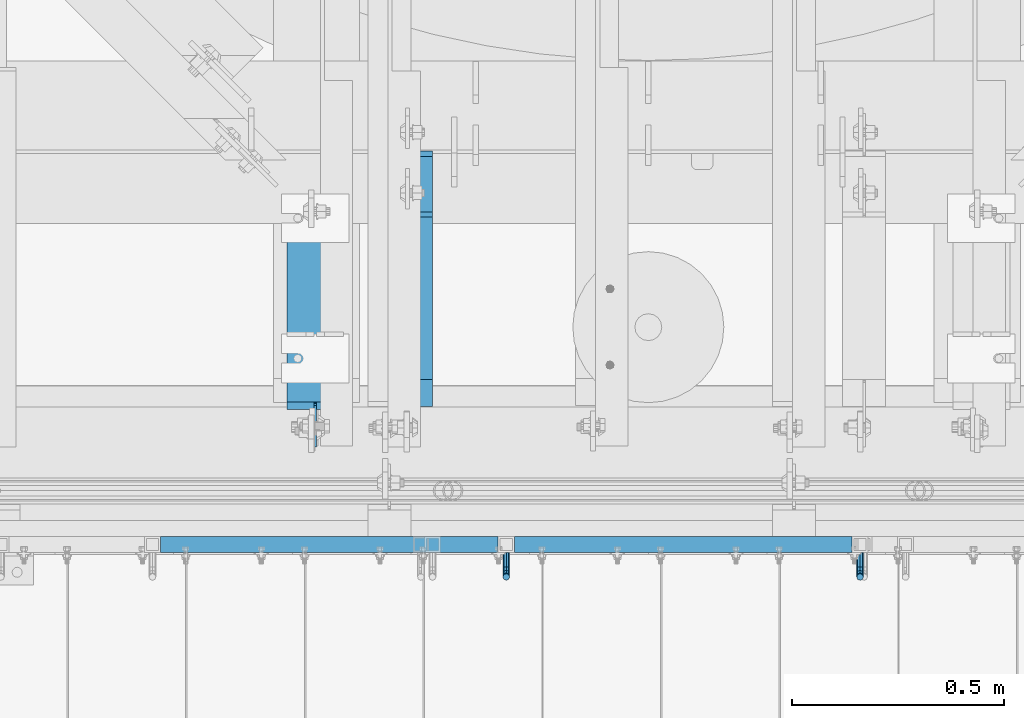
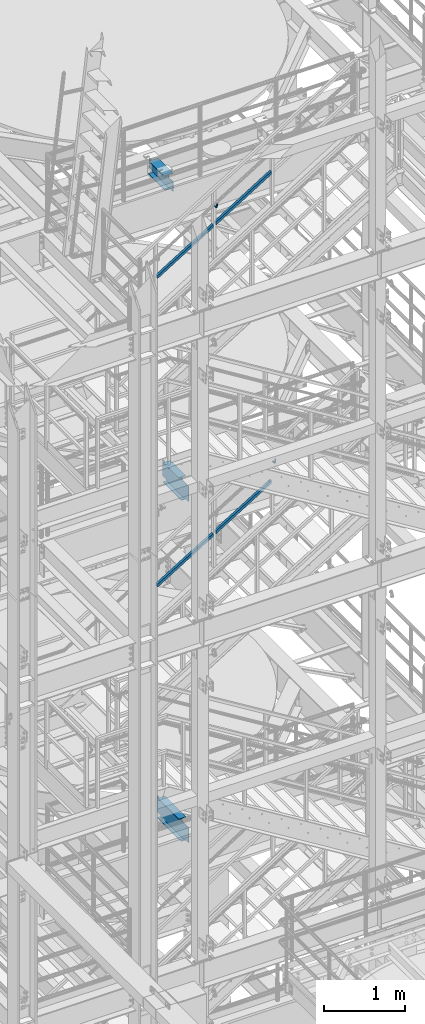
# One storey, part 1191 of 1876: 5 beams, 4 members, 5 elements without a shape of their own.
"""IFC2X3 building model written with IfcOpenShell, lengths in millimetres."""

from ifc_helpers import new_model, si_unit, frame, origin_with_axes, place, context, subcontext, project, spatial, faceted_brep, material, type_object, element, aggregate, save


model = new_model("IFC2X3")

# Units and contexts
model_context = context("Model", 3, precision=1e-05, world=origin_with_axes())
body_context = subcontext(model_context, "Body", "Model", "MODEL_VIEW")
ifc_project = project(units=[si_unit("LENGTHUNIT", "METRE", prefix="MILLI"), si_unit("AREAUNIT", "SQUARE_METRE"), si_unit("VOLUMEUNIT", "CUBIC_METRE"), si_unit("MASSUNIT", "GRAM", prefix="KILO"), si_unit("TIMEUNIT", "SECOND"), si_unit("PLANEANGLEUNIT", "RADIAN"), si_unit("SOLIDANGLEUNIT", "STERADIAN"), si_unit("THERMODYNAMICTEMPERATUREUNIT", "DEGREE_CELSIUS"), si_unit("LUMINOUSINTENSITYUNIT", "LUMEN")], contexts=[model_context])

# Site, building, storey
site_placement = place(None, origin_with_axes())
site = spatial("IfcSite", under=ifc_project, at=site_placement, CompositionType="ELEMENT")
building_placement = place(site_placement, origin_with_axes())
building = spatial("IfcBuilding", under=site, at=building_placement, Name="Undefined", CompositionType="ELEMENT")
storey_placement = place(building_placement, origin_with_axes())
storey = spatial("IfcBuildingStorey", under=building, at=storey_placement, Name="Undefined", CompositionType="ELEMENT", Elevation=0.0)

# Assembly, beam
assembly_1_placement = place(storey_placement, origin_with_axes())
assembly_1 = element("IfcElementAssembly", 1, at=assembly_1_placement, inside=storey, Name="BEAM", AssemblyPlace="NOTDEFINED", PredefinedType="RIGID_FRAME")
ifc_material_1 = material(Name="STEEL/A992")
beam_type_1 = type_object("IfcBeamType", Name="W12X16", PredefinedType="NOTDEFINED")
beam_1_placement = place(assembly_1_placement, frame((3860.8, -4572.0, 13157.2), z_axis=(0.0, 0.0, 1.0), x_axis=(0.0, 1.0, 0.0)))
beam_1 = element("IfcBeam", 2, at=beam_1_placement, type_object=beam_type_1, material=ifc_material_1, Name="BEAM", ObjectType="W12X16", context=body_context, shape_type="Brep", body=[
    faceted_brep([(573.881250000001, -3.17500000000018, -146.049999999999), (573.881250000001, -50.8000000000002, -146.049999999999), (573.881250000001, -50.8000000000002, -152.4), (573.881250000001, 50.8000000000002, -152.4), (573.881250000001, 50.8000000000002, -146.049999999999), (573.881250000001, 3.17500000000018, -146.049999999999), (573.881250000001, 3.17500000000018, -139.699999809265), (573.881250000001, -3.17500000000018, -139.699999809265), (574.847979922589, 3.17500000000018, -134.839920291219), (574.847979922589, -3.17500000000018, -134.839920291219), (577.600993823067, 3.17500000000018, -130.719743823065), (577.600993823067, -3.17500000000018, -130.719743823065), (581.72117029122, 3.17500000000018, -127.966729922588), (581.72117029122, -3.17500000000018, -127.966729922588), (586.581249809266, 3.17500000000018, -127.0), (586.581249809266, -3.17500000000018, -127.0), (662.78125, -3.17500000000018, -127.0), (662.78125, 3.17500000000018, -127.0), (179.3875, 3.17500000000018, 146.049999999999), (179.3875, 50.8000000000002, 146.049999999999), (561.181250000001, 50.8000000000002, 146.049999999999), (561.181250000001, 3.17500000000018, 146.049999999999), (115.8875, -3.17500000000018, -139.699999809263), (115.8875, 3.17500000000018, -139.699999809263), (115.8875, 3.17500000000018, -146.049999999999), (115.8875, 50.8000000000002, -146.049999999999), (115.8875, 50.8000000000002, -152.4), (115.8875, -50.8000000000002, -152.4), (115.8875, -50.8000000000002, -146.049999999999), (115.8875, -3.17500000000018, -146.049999999999), (114.920770077412, -3.17500000000018, -134.839920291217), (114.920770077412, 3.17500000000018, -134.839920291217), (112.167756176934, -3.17500000000018, -130.719743823063), (112.167756176934, 3.17500000000018, -130.719743823063), (108.04757970878, -3.17500000000018, -127.966729922586), (108.04757970878, 3.17500000000018, -127.966729922586), (103.187500190735, -3.17500000000018, -126.999999999998), (103.187500190735, 3.17500000000018, -126.999999999998), (20.6374999999998, -3.17500000000018, -126.999999999998), (20.6374999999998, 3.17500000000018, -126.999999999998), (20.6374999999998, -3.17500000000018, 101.600000000002), (20.6374999999998, 3.17500000000018, 101.600000000002), (166.687500190735, -3.17500000000018, 101.600000000002), (166.687500190735, 3.17500000000018, 101.600000000002), (171.54757970878, -3.17500000000018, 102.56672992259), (171.54757970878, 3.17500000000018, 102.56672992259), (175.667756176934, -3.17500000000018, 105.319743823067), (175.667756176934, 3.17500000000018, 105.319743823067), (178.420770077412, -3.17500000000018, 109.439920291221), (178.420770077412, 3.17500000000018, 109.439920291221), (179.3875, -3.17500000000018, 114.299999809267), (179.3875, 3.17500000000018, 114.299999809267), (179.3875, -50.8000000000002, 152.4), (179.3875, 50.8000000000002, 152.4), (179.3875, -3.17500000000018, 146.049999999999), (179.3875, -50.8000000000002, 146.049999999999), (561.181250000001, -3.17500000000018, 146.049999999999), (561.181250000001, -50.8000000000002, 146.049999999999), (561.181250000001, -50.8000000000002, 152.4), (561.181250000001, 50.8000000000002, 152.4), (561.181250000001, -3.17500000000018, 133.349999809265), (561.181250000001, 3.17500000000018, 133.349999809265), (562.147979922589, -3.17500000000018, 128.489920291218), (562.147979922589, 3.17500000000018, 128.489920291218), (564.900993823067, -3.17500000000018, 124.369743823065), (564.900993823067, 3.17500000000018, 124.369743823065), (569.021170291221, -3.17500000000018, 121.616729922587), (569.021170291221, 3.17500000000018, 121.616729922587), (573.881249809266, -3.17500000000018, 120.65), (573.881249809266, 3.17500000000018, 120.65), (662.78125, -3.17500000000018, 120.65), (662.78125, 3.17500000000018, 120.65)], [[[0, 1, 2, 3, 4, 5, 6, 7]], [[7, 6, 8, 9]], [[9, 8, 10, 11]], [[11, 10, 12, 13]], [[13, 12, 14, 15]], [[16, 15, 14, 17]], [[18, 19, 20, 21]], [[22, 23, 24, 25, 26, 27, 28, 29]], [[30, 31, 23, 22]], [[32, 33, 31, 30]], [[34, 35, 33, 32]], [[36, 37, 35, 34]], [[38, 39, 37, 36]], [[40, 41, 39, 38]], [[42, 43, 41, 40]], [[44, 45, 43, 42]], [[46, 47, 45, 44]], [[48, 49, 47, 46]], [[50, 51, 49, 48]], [[52, 53, 19, 18, 51, 50, 54, 55]], [[55, 54, 56, 57]], [[52, 55, 57, 58]], [[53, 52, 58, 59]], [[19, 53, 59, 20]], [[58, 57, 56, 60, 61, 21, 20, 59]], [[62, 63, 61, 60]], [[64, 65, 63, 62]], [[66, 67, 65, 64]], [[68, 69, 67, 66]], [[70, 71, 69, 68]], [[71, 70, 16, 17]], [[12, 10, 8, 6, 5, 24, 23, 31, 33, 35, 37, 39, 41, 43, 45, 47, 49, 51, 18, 21, 61, 63, 65, 67, 69, 71, 17, 14]], [[25, 24, 5, 4]], [[26, 25, 4, 3]], [[27, 26, 3, 2]], [[28, 27, 2, 1]], [[29, 28, 1, 0]], [[70, 68, 66, 64, 62, 60, 56, 54, 50, 48, 46, 44, 42, 40, 38, 36, 34, 32, 30, 22, 29, 0, 7, 9, 11, 13, 15, 16]]]),
])
aggregate(assembly_1, [beam_1])

assembly_2_placement = place(storey_placement, origin_with_axes())
assembly_2 = element("IfcElementAssembly", 3, at=assembly_2_placement, inside=storey, Name="BEAM", AssemblyPlace="NOTDEFINED", PredefinedType="RIGID_FRAME")
beam_2_placement = place(assembly_2_placement, frame((3860.8, -4572.0, 8001.0), z_axis=(0.0, 0.0, 1.0), x_axis=(0.0, 1.0, 0.0)))
beam_2 = element("IfcBeam", 4, at=beam_2_placement, type_object=beam_type_1, material=ifc_material_1, Name="BEAM", ObjectType="W12X16", context=body_context, shape_type="Brep", body=[
    faceted_brep([(716.75625, -3.17500000000018, -146.05), (716.75625, -50.8000000000002, -146.05), (716.75625, -50.8000000000002, -152.4), (716.75625, 50.8000000000002, -152.4), (716.75625, 50.8000000000002, -146.05), (716.75625, 3.17500001244935, -146.05), (716.75625, 3.17500003927307, -139.699999809264), (716.75625, -3.17500000000018, -139.699999809264), (717.722979922588, 3.17500003847817, -134.839920291219), (717.722979922588, -3.17500000000018, -134.839920291219), (720.475993823066, 3.17500003779696, -130.719743823065), (720.475993823066, -3.17500000000018, -130.719743823065), (724.59617029122, 3.17500003733312, -127.966729922587), (724.59617029122, -3.17500000000018, -127.966729922587), (729.456249809265, 3.17500003715577, -126.999999999999), (729.456249809265, -3.17500000000018, -126.999999999999), (805.65625, -3.17500000000018, -126.999999999999), (805.65625, 3.17500000000018, -126.999999999999), (181.768749999998, 3.17499999999995, 146.05), (181.768749999998, 50.8, 146.05), (704.05625, 50.8000000000002, 146.05), (704.05625, 3.17500000000018, 146.05), (124.61875, 50.8, -146.05), (124.61875, 50.8, -152.4), (124.61875, 3.17500009536752, -152.4), (124.61875, 3.17500009536752, -146.05), (118.268749999998, 3.17500009536752, -152.4), (118.268749999998, 3.17500008940715, -146.05), (118.268749999998, -3.17499999999995, -139.699999809265), (118.268749999998, 3.17500002616043, -139.699999809265), (118.268749999998, -50.8, -152.4), (118.268749999998, -50.8, -146.05), (118.268749999998, -3.17499999999995, -146.05), (117.302020077411, -3.17499999999995, -134.83992029122), (117.302020077411, 3.17500002537099, -134.83992029122), (114.549006176932, -3.17499999999995, -130.719743823066), (114.549006176932, 3.17500002470138, -130.719743823066), (110.428829708779, -3.17499999999995, -127.966729922588), (110.428829708779, 3.17500002425345, -127.966729922588), (105.568750190733, -3.17499999999995, -127.0), (105.568750190733, 3.17500002409543, -127.0), (23.0187500000002, -3.17499999999995, -127.0), (23.0187500000002, 3.17499999999995, -127.0), (23.0187500000002, -3.17499999999995, 101.6), (23.0187500000002, 3.17499999999995, 101.6), (169.068750190733, -3.17499999999995, 101.6), (169.068750190733, 3.17499998798007, 101.6), (173.928829708779, -3.17499999999995, 102.566729922588), (173.928829708779, 3.17499998782432, 102.566729922588), (178.049006176932, -3.17499999999995, 105.319743823066), (178.049006176932, 3.17499998738072, 105.319743823066), (180.802020077411, -3.17499999999995, 109.43992029122), (180.802020077411, 3.17499998671678, 109.43992029122), (181.768749999998, -3.17499999999995, 114.299999809266), (181.768749999998, 3.17499998593348, 114.299999809266), (181.768749999998, -50.8, 152.4), (181.768749999998, 50.8, 152.4), (181.768749999998, -3.17499999999995, 146.05), (181.768749999998, -50.8, 146.05), (704.05625, -3.17500000000018, 146.05), (704.05625, -50.8000000000002, 146.05), (704.05625, -50.8000000000002, 152.4), (704.05625, 50.8000000000002, 152.4), (704.05625, -3.17500000000018, 133.349999809266), (704.05625, 3.1749999952408, 133.349999809266), (705.022979922588, -3.17500000000018, 128.48992029122), (705.022979922588, 3.17499999601478, 128.48992029122), (707.775993823066, -3.17500000000018, 124.369743823067), (707.775993823066, 3.17499999666416, 124.369743823067), (711.89617029122, -3.17500000000018, 121.616729922588), (711.89617029122, 3.1749999970898, 121.616729922588), (716.756249809265, -3.17500000000018, 120.650000000001), (716.756249809265, 3.17499999722713, 120.650000000001), (805.65625, -3.17500000000018, 120.650000000001), (805.65625, 3.17500000000018, 120.650000000001)], [[[0, 1, 2, 3, 4, 5, 6, 7]], [[7, 6, 8, 9]], [[9, 8, 10, 11]], [[11, 10, 12, 13]], [[13, 12, 14, 15]], [[16, 15, 14, 17]], [[18, 19, 20, 21]], [[22, 23, 24, 25]], [[25, 24, 26, 27]], [[28, 29, 27, 26, 30, 31, 32]], [[33, 34, 29, 28]], [[35, 36, 34, 33]], [[37, 38, 36, 35]], [[39, 40, 38, 37]], [[41, 42, 40, 39]], [[43, 44, 42, 41]], [[45, 46, 44, 43]], [[47, 48, 46, 45]], [[49, 50, 48, 47]], [[51, 52, 50, 49]], [[53, 54, 52, 51]], [[55, 56, 19, 18, 54, 53, 57, 58]], [[58, 57, 59, 60]], [[55, 58, 60, 61]], [[56, 55, 61, 62]], [[19, 56, 62, 20]], [[61, 60, 59, 63, 64, 21, 20, 62]], [[65, 66, 64, 63]], [[67, 68, 66, 65]], [[69, 70, 68, 67]], [[71, 72, 70, 69]], [[73, 74, 72, 71]], [[74, 73, 16, 17]], [[12, 10, 8, 6, 5, 25, 27, 29, 34, 36, 38, 40, 42, 44, 46, 48, 50, 52, 54, 18, 21, 64, 66, 68, 70, 72, 74, 17, 14]], [[22, 25, 5, 4]], [[23, 22, 4, 3]], [[30, 26, 24, 23, 3, 2]], [[31, 30, 2, 1]], [[32, 31, 1, 0]], [[73, 71, 69, 67, 65, 63, 59, 57, 53, 51, 49, 47, 45, 43, 41, 39, 37, 35, 33, 28, 32, 0, 7, 9, 11, 13, 15, 16]]]),
])
aggregate(assembly_2, [beam_2])

assembly_3_placement = place(storey_placement, origin_with_axes())
assembly_3 = element("IfcElementAssembly", 5, at=assembly_3_placement, inside=storey, Name="RAIL", AssemblyPlace="NOTDEFINED", PredefinedType="RIGID_FRAME")
ifc_material_2 = material(Name="STEEL/A36")
beam_type_2 = type_object("IfcBeamType", PredefinedType="NOTDEFINED")
beam_3_placement = place(assembly_3_placement, frame((4918.07499998295, -4800.59999885446, 13420.0225827667), z_axis=(1.0, 0.0, 0.0), x_axis=(0.0, -1.0, 0.0)))
beam_3 = element("IfcBeam", 6, at=beam_3_placement, type_object=beam_type_2, material=ifc_material_2, Name="BRACKET", context=body_context, shape_type="Brep", body=[
    faceted_brep([(0.0, -5.61266007566822, 5.61266007566883), (0.0, 0.0, 7.9375), (0.0, 5.61266007566822, 5.61266007566883), (0.0, 7.9375, 0.0), (0.0, 5.61266007566822, -5.61266007566883), (0.0, 0.0, -7.9375), (0.0, -5.61266007566822, -5.61266007566883), (0.0, -7.9375, 0.0), (23.8125, 5.61266007566883, 5.61266007566792), (23.8125, 7.9375, 0.0), (23.8125, 5.61266007566883, -5.61266007566792), (23.8125, 0.0, -7.9375), (23.8125, -5.61266007566883, -5.61266007566792), (23.8125, -7.9375, 0.0), (23.8125, -5.61266007566883, 5.61266007566792), (23.8125, 0.0, 7.9375), (36.5702095103989, -2.53766620105534, 7.9375), (38.7180815328547, 2.64775556579752, 5.61266007566792), (39.6077592547972, 4.79562758825296, 0.0), (38.7180815328547, 2.64775556579752, -5.61266007566792), (36.5702095103989, -2.53766620105534, -7.9375), (34.4223374879439, -7.72308796790867, -5.61266007566792), (33.5326597660014, -9.87095999036364, 0.0), (34.4223374879439, -7.72308796790867, 5.61266007566792), (43.4169233967659, -13.733078129113, 5.61266007566792), (47.385673396765, -9.76432812911298, 7.9375), (41.7730133210971, -15.3769882047809, 0.0), (43.4169233967659, -13.733078129113, -5.61266007566792), (47.385673396765, -9.76432812911298, -7.9375), (51.354423396765, -5.79557812911253, -5.61266007566792), (52.9983334724338, -4.15166805344461, 0.0), (51.354423396765, -5.79557812911253, 5.61266007566792), (54.6123353248231, -20.5797920154787, 7.9375), (59.7977570916764, -18.4319199930233, 5.61266007566792), (49.4269135579698, -22.7276640379341, 5.61266007566792), (47.2790415355148, -23.6173417598766, 0.0), (49.4269135579698, -22.7276640379341, -5.61266007566792), (54.6123353248231, -20.5797920154787, -7.9375), (59.7977570916764, -18.4319199930233, -5.61266007566792), (61.9456291141314, -17.5422422710808, 0.0), (62.7626616015468, -33.3375015258789, 5.61266007566792), (65.0875015258789, -33.3375015258789, 0.0), (57.1500015258789, -33.3375015258789, 7.9375), (51.5373414502101, -33.3375015258789, 5.61266007566792), (49.2125015258789, -33.3375015258789, 0.0), (51.5373414502101, -33.3375015258789, -5.61266007566792), (57.1500015258789, -33.3375015258789, -7.9375), (62.7626616015468, -33.3375015258789, -5.61266007566792), (65.0875015258789, -66.5341532333514, 2.45290721068159e-09), (62.7626616015805, -63.0815171359536, -5.61266007334871), (57.1500015259289, -61.6513884384531, -7.93749999776537), (51.5373414502437, -63.0815171359118, -5.6126600734151), (49.2125015258789, -66.5341532333259, 2.41197994910181e-09), (51.5373414501864, -69.9867893307037, 5.61266007818085), (57.1500015258471, -71.4169180281988, 7.93750000258842), (62.7626616015223, -69.9867893307346, 5.61266007822906)], [[[0, 1, 2, 3, 4, 5, 6, 7]], [[3, 2, 8, 9]], [[4, 3, 9, 10]], [[5, 4, 10, 11]], [[6, 5, 11, 12]], [[7, 6, 12, 13]], [[0, 7, 13, 14]], [[1, 0, 14, 15]], [[2, 1, 15, 8]], [[8, 15, 16, 17]], [[9, 8, 17, 18]], [[10, 9, 18, 19]], [[11, 10, 19, 20]], [[12, 11, 20, 21]], [[13, 12, 21, 22]], [[14, 13, 22, 23]], [[15, 14, 23, 16]], [[23, 24, 25, 16]], [[22, 26, 24, 23]], [[21, 27, 26, 22]], [[20, 28, 27, 21]], [[19, 29, 28, 20]], [[18, 30, 29, 19]], [[17, 31, 30, 18]], [[16, 25, 31, 17]], [[25, 32, 33, 31]], [[24, 34, 32, 25]], [[26, 35, 34, 24]], [[27, 36, 35, 26]], [[28, 37, 36, 27]], [[29, 38, 37, 28]], [[30, 39, 38, 29]], [[31, 33, 39, 30]], [[33, 40, 41, 39]], [[32, 42, 40, 33]], [[34, 43, 42, 32]], [[35, 44, 43, 34]], [[36, 45, 44, 35]], [[37, 46, 45, 36]], [[38, 47, 46, 37]], [[39, 41, 47, 38]], [[47, 41, 48, 49]], [[46, 47, 49, 50]], [[45, 46, 50, 51]], [[44, 45, 51, 52]], [[43, 44, 52, 53]], [[42, 43, 53, 54]], [[40, 42, 54, 55]], [[41, 40, 55, 48]], [[54, 53, 52, 51, 50, 49, 48, 55]]]),
])

assembly_4_placement = place(storey_placement, origin_with_axes())
assembly_4 = element("IfcElementAssembly", 7, at=assembly_4_placement, inside=storey, Name="RAIL", AssemblyPlace="NOTDEFINED", PredefinedType="RIGID_FRAME")
beam_4_placement = place(assembly_4_placement, frame((4085.16666479088, -4800.60000114554, 17572.4589985402), z_axis=(-1.0, 0.0, 0.0), x_axis=(0.0, -1.0, 0.0)))
beam_4 = element("IfcBeam", 8, at=beam_4_placement, type_object=beam_type_2, material=ifc_material_2, Name="BRACKET", context=body_context, shape_type="Brep", body=[
    faceted_brep([(0.0, -5.61266007566822, 5.61266007566883), (0.0, 0.0, 7.9375), (0.0, 5.61266007566822, 5.61266007566883), (0.0, 7.9375, 0.0), (0.0, 5.61266007566822, -5.61266007566883), (0.0, 0.0, -7.9375), (0.0, -5.61266007566822, -5.61266007566883), (0.0, -7.9375, 0.0), (23.8125, -5.61266007566883, -5.61266007566792), (23.8125, -7.9375, 0.0), (23.8125, -5.61266007566883, 5.61266007566792), (23.8125, 0.0, 7.9375), (23.8125, 5.61266007566883, 5.61266007566792), (23.8125, 7.9375, 0.0), (23.8125, 5.61266007566883, -5.61266007566792), (23.8125, 0.0, -7.9375), (36.5702095103998, 2.53766620105671, -7.9375), (38.7180815328556, -2.64775556579843, -5.61266007566792), (39.6077592547981, -4.79562758825341, 0.0), (38.7180815328556, -2.64775556579843, 5.61266007566792), (36.5702095103998, 2.53766620105671, 7.9375), (34.4223374879448, 7.72308796790821, 5.61266007566792), (33.5326597660023, 9.87095999036319, 0.0), (34.4223374879448, 7.72308796790821, -5.61266007566792), (43.4169233967659, 13.733078129113, -5.61266007566792), (47.3856733967659, 9.76432812911298, -7.9375), (41.773013321098, 15.3769882047818, 0.0), (43.4169233967659, 13.733078129113, 5.61266007566792), (47.3856733967659, 9.76432812911298, 7.9375), (51.3544233967659, 5.79557812911298, 5.61266007566792), (52.9983334724348, 4.15166805344415, 0.0), (51.3544233967659, 5.79557812911298, -5.61266007566792), (54.6123353248231, 20.5797920154801, -7.9375), (59.7977570916764, 18.4319199930251, -5.61266007566792), (49.4269135579698, 22.727664037935, -5.61266007566792), (47.2790415355148, 23.6173417598766, 0.0), (49.4269135579698, 22.727664037935, 5.61266007566792), (54.6123353248231, 20.5797920154801, 7.9375), (59.7977570916764, 18.4319199930251, 5.61266007566792), (61.9456291141314, 17.5422422710835, 0.0), (62.7626616015468, 33.3375015258789, -5.61266007566792), (65.0875015258789, 33.3375015258789, 0.0), (57.1500015258789, 33.3375015258789, -7.9375), (51.5373414502101, 33.3375015258789, -5.61266007566792), (49.2125015258789, 33.3375015258789, 0.0), (51.5373414502101, 33.3375015258789, 5.61266007566792), (57.1500015258789, 33.3375015258789, 7.9375), (62.7626616015468, 33.3375015258789, 5.61266007566792), (65.0875015258789, 66.4903820289292, 0.0), (62.7626616015468, 63.0131702244908, 5.61266007566837), (57.1500015258789, 61.5728619358488, 7.9375), (51.537341450211, 63.0131702244908, 5.61266007566837), (49.2125015258789, 66.4903820289292, 0.0), (51.537341450211, 69.9675938333676, -5.61266007566837), (57.1500015258789, 71.4079021220132, -7.9375), (62.7626616015468, 69.9675938333676, -5.61266007566837)], [[[0, 1, 2, 3, 4, 5, 6, 7]], [[7, 6, 8, 9]], [[0, 7, 9, 10]], [[1, 0, 10, 11]], [[2, 1, 11, 12]], [[3, 2, 12, 13]], [[4, 3, 13, 14]], [[5, 4, 14, 15]], [[6, 5, 15, 8]], [[8, 15, 16, 17]], [[9, 8, 17, 18]], [[10, 9, 18, 19]], [[11, 10, 19, 20]], [[12, 11, 20, 21]], [[13, 12, 21, 22]], [[14, 13, 22, 23]], [[15, 14, 23, 16]], [[23, 24, 25, 16]], [[22, 26, 24, 23]], [[21, 27, 26, 22]], [[20, 28, 27, 21]], [[19, 29, 28, 20]], [[18, 30, 29, 19]], [[17, 31, 30, 18]], [[16, 25, 31, 17]], [[25, 32, 33, 31]], [[24, 34, 32, 25]], [[26, 35, 34, 24]], [[27, 36, 35, 26]], [[28, 37, 36, 27]], [[29, 38, 37, 28]], [[30, 39, 38, 29]], [[31, 33, 39, 30]], [[33, 40, 41, 39]], [[32, 42, 40, 33]], [[34, 43, 42, 32]], [[35, 44, 43, 34]], [[36, 45, 44, 35]], [[37, 46, 45, 36]], [[38, 47, 46, 37]], [[39, 41, 47, 38]], [[47, 41, 48, 49]], [[46, 47, 49, 50]], [[45, 46, 50, 51]], [[44, 45, 51, 52]], [[43, 44, 52, 53]], [[42, 43, 53, 54]], [[40, 42, 54, 55]], [[41, 40, 55, 48]], [[54, 53, 52, 51, 50, 49, 48, 55]]]),
])

# Member
ifc_material_3 = material()
member_type = type_object("IfcMemberType", Name="HSS1-1/2X1-1/2X1/8", PredefinedType="NOTDEFINED")
member_1_placement = place(assembly_3_placement, frame((4085.16666677336, -4781.55000114554, 12615.5578279455), z_axis=(-0.523953411146183, 0.0, 0.851746924237639), x_axis=(0.851746924237639, 0.0, 0.523953411146184)))
member_1 = element("IfcMember", 9, at=member_1_placement, type_object=member_type, material=ifc_material_3, Name="RAIL", ObjectType="HSS1-1/2X1-1/2X1/8", context=body_context, shape_type="Brep", body=[
    faceted_brep([(10.6471616099025, -19.0499992349996, -19.0499992350033), (34.0844334038557, -19.0499992349996, 19.0499992349978), (34.0844334038557, 19.0499992349996, 19.0499992349978), (10.6471616099025, 19.0499992349996, -19.0499992350033), (32.1313273721225, 15.8749992829999, 15.874999282998), (32.1313273721225, -15.8749992829999, 15.874999282998), (12.6002676416374, -15.8749992829999, -15.8749992830035), (12.6002676416374, 15.8749992829999, -15.8749992830035), (943.797974516105, 19.0499992349996, -19.0499992349924), (943.797974516105, -19.0499992349996, -19.0499992349924), (967.235246310049, -19.0499992349996, 19.0499992350105), (967.235246310049, 19.0499992349996, 19.0499992350105), (965.282140278314, -15.8749992829999, 15.8749992830126), (965.282140278314, 15.8749992829999, 15.8749992830126), (945.751080547838, 15.8749992829999, -15.8749992829926), (945.751080547838, -15.8749992829999, -15.8749992829926)], [[[0, 1, 2, 3], [4, 5, 6, 7]], [[8, 9, 0, 3]], [[9, 10, 1, 0]], [[10, 11, 2, 1]], [[11, 8, 3, 2]], [[10, 9, 8, 11], [12, 13, 14, 15]], [[13, 12, 5, 4]], [[14, 13, 4, 7]], [[15, 14, 7, 6]], [[12, 15, 6, 5]]]),
])

member_2_placement = place(assembly_3_placement, frame((3252.25833356129, -4781.55000114554, 12103.193004616), z_axis=(-0.523953411146183, 0.0, 0.851746924237639), x_axis=(0.851746924237639, 0.0, 0.523953411146184)))
member_2 = element("IfcMember", 10, at=member_2_placement, type_object=member_type, material=ifc_material_3, Name="RAIL", ObjectType="HSS1-1/2X1-1/2X1/8", context=body_context, shape_type="Brep", body=[
    faceted_brep([(967.235246310049, -19.0499992349996, 19.0499992350105), (943.797974516105, -19.0499992349996, -19.0499992349924), (943.797974516105, 19.0499992349996, -19.0499992349924), (967.235246310049, 19.0499992349996, 19.0499992350105), (965.282140278314, -15.8749992829999, 15.8749992830126), (965.282140278314, 15.8749992829999, 15.8749992830126), (945.751080547838, 15.8749992829999, -15.8749992829926), (945.751080547838, -15.8749992829999, -15.8749992829926), (10.6471616099025, 19.0499992349996, -19.0499992350033), (34.0844334038557, 19.0499992349996, 19.0499992349978), (34.0844334038557, -19.0499992349996, 19.0499992349978), (10.6471616099025, -19.0499992349996, -19.0499992350033), (32.1313273721225, 15.8749992829999, 15.874999282998), (32.1313273721225, -15.8749992829999, 15.874999282998), (12.6002676416374, -15.8749992829999, -15.8749992830035), (12.6002676416374, 15.8749992829999, -15.8749992830035)], [[[0, 1, 2, 3], [4, 5, 6, 7]], [[3, 2, 8, 9]], [[0, 3, 9, 10]], [[1, 0, 10, 11]], [[2, 1, 11, 8]], [[11, 10, 9, 8], [12, 13, 14, 15]], [[4, 7, 14, 13]], [[7, 6, 15, 14]], [[6, 5, 12, 15]], [[5, 4, 13, 12]]]),
])

aggregate(assembly_3, [beam_3, member_1, member_2])

member_3_placement = place(assembly_4_placement, frame((3252.2583323442, -4781.55000114554, 16764.4514718277), z_axis=(-0.526627379729772, 0.0, 0.850096231563789), x_axis=(0.850096231563789, 0.0, 0.526627379729772)))
member_3 = element("IfcMember", 11, at=member_3_placement, type_object=member_type, material=ifc_material_3, Name="RAIL", ObjectType="HSS1-1/2X1-1/2X1/8", context=body_context, shape_type="Brep", body=[
    faceted_brep([(969.17331595645, -19.0499992349996, 19.0499992348905), (945.570691198265, -19.0499992349996, -19.049999235076), (945.570691198265, 19.0499992349996, -19.049999235076), (969.17331595645, 19.0499992349996, 19.0499992348905), (967.206430510685, -15.8749992829999, 15.8749992828944), (967.206430510685, 15.8749992829999, 15.8749992828944), (947.53757664403, 15.8749992829999, -15.8749992830781), (947.53757664403, -15.8749992829999, -15.8749992830781), (10.6079144021951, 19.0499992349996, -19.0499992349669), (34.210539160511, 19.0499992349996, 19.0499992350342), (34.210539160511, -19.0499992349996, 19.0499992350342), (10.6079144021951, -19.0499992349996, -19.0499992349669), (32.243653714735, 15.8749992829999, 15.8749992830344), (32.243653714735, -15.8749992829999, 15.8749992830344), (12.574799847971, -15.8749992829999, -15.8749992829671), (12.574799847971, 15.8749992829999, -15.8749992829671)], [[[0, 1, 2, 3], [4, 5, 6, 7]], [[8, 9, 3, 2]], [[9, 10, 0, 3]], [[10, 11, 1, 0]], [[11, 8, 2, 1]], [[11, 10, 9, 8], [12, 13, 14, 15]], [[14, 13, 4, 7]], [[15, 14, 7, 6]], [[12, 15, 6, 5]], [[13, 12, 5, 4]]]),
])

member_4_placement = place(assembly_4_placement, frame((4085.16666479254, -4781.55000114554, 17280.4310943592), z_axis=(-0.526627379729772, 0.0, 0.850096231563789), x_axis=(0.850096231563789, 0.0, 0.526627379729772)))
member_4 = element("IfcMember", 12, at=member_4_placement, type_object=member_type, material=ifc_material_3, Name="RAIL", ObjectType="HSS1-1/2X1-1/2X1/8", context=body_context, shape_type="Brep", body=[
    faceted_brep([(10.6079144021951, -19.0499992349996, -19.0499992349669), (34.210539160511, -19.0499992349996, 19.0499992350342), (34.210539160511, 19.0499992349996, 19.0499992350342), (10.6079144021951, 19.0499992349996, -19.0499992349669), (32.243653714735, 15.8749992829999, 15.8749992830344), (32.243653714735, -15.8749992829999, 15.8749992830344), (12.574799847971, -15.8749992829999, -15.8749992829671), (12.574799847971, 15.8749992829999, -15.8749992829671), (945.570691198265, 19.0499992349996, -19.049999235076), (945.570691198265, -19.0499992349996, -19.049999235076), (969.17331595645, -19.0499992349996, 19.0499992348905), (969.17331595645, 19.0499992349996, 19.0499992348905), (967.206430510685, -15.8749992829999, 15.8749992828944), (967.206430510685, 15.8749992829999, 15.8749992828944), (947.53757664403, 15.8749992829999, -15.8749992830781), (947.53757664403, -15.8749992829999, -15.8749992830781)], [[[0, 1, 2, 3], [4, 5, 6, 7]], [[0, 3, 8, 9]], [[1, 0, 9, 10]], [[2, 1, 10, 11]], [[3, 2, 11, 8]], [[10, 9, 8, 11], [12, 13, 14, 15]], [[5, 4, 13, 12]], [[4, 7, 14, 13]], [[7, 6, 15, 14]], [[6, 5, 12, 15]]]),
])

aggregate(assembly_4, [beam_4, member_3, member_4])

# Assembly, beam
assembly_5_placement = place(storey_placement, origin_with_axes())
assembly_5 = element("IfcElementAssembly", 13, at=assembly_5_placement, inside=storey, Name="BEAM", AssemblyPlace="NOTDEFINED", PredefinedType="RIGID_FRAME")
beam_type_3 = type_object("IfcBeamType", Name="W8X18", PredefinedType="NOTDEFINED")
beam_5_placement = place(assembly_5_placement, frame((3635.375, -4572.0, 17880.0125), z_axis=(0.0, 0.0, 1.0), x_axis=(0.0, 1.0, 0.0)))
beam_5 = element("IfcBeam", 14, at=beam_5_placement, type_object=beam_type_3, material=ifc_material_1, Name="BEAM", ObjectType="W8X18", context=body_context, shape_type="Brep", body=[
    faceted_brep([(19.84375, -3.17500000000018, -84.1374999999971), (19.84375, 3.17500000000018, -84.1374999999971), (96.0437501907345, 3.17500002296038, -84.1374999999971), (96.0437501907345, -3.17500000000018, -84.1374999999971), (100.90382970878, 3.17500002319775, -85.1042299225846), (100.90382970878, -3.17500000000018, -85.1042299225846), (105.024006176934, 3.17500002384804, -87.8572438230622), (105.024006176934, -3.17500000000018, -87.8572438230622), (107.777020077412, 3.17500002481211, -91.9774202912158), (107.777020077412, -3.17500000000018, -91.9774202912158), (108.74375, -66.6750000000002, -96.8374998092622), (108.74375, 66.6750000000002, -96.8374998092622), (108.74375, 66.6750000000002, -103.1875), (108.74375, -66.6750000000002, -103.1875), (108.427976654724, -66.6750000000002, -95.25), (108.427976654724, -3.17500000000018, -95.25), (108.427976654724, 3.17500009258674, -95.25), (108.427976654724, 66.6750000000002, -95.25), (504.825000000001, 66.6750000000002, 95.25), (504.825000000001, 3.17500000000018, 95.25), (126.20625, 3.17500000000018, 95.25), (126.20625, 66.6750000000002, 95.25), (113.506250190735, -3.17500000000018, 58.7375000000029), (113.506250190735, 3.17499999062875, 58.7375000000029), (19.84375, 3.17500000000018, 58.7375000000029), (19.84375, -3.17500000000018, 58.7375000000029), (118.366329708781, -3.17500000000018, 59.7042299225905), (118.366329708781, 3.17499999041775, 59.7042299225905), (122.486506176934, -3.17500000000018, 62.457243823068), (122.486506176934, 3.17499998979656, 62.457243823068), (125.239520077413, -3.17500000000018, 66.5774202912216), (125.239520077413, 3.17499998886069, 66.5774202912216), (126.20625, -3.17500000000018, 71.437499809268), (126.20625, 3.17499998775293, 71.437499809268), (504.825000000001, -66.6750000000002, 103.1875), (504.825000000001, 66.6750000000002, 103.1875), (126.20625, 66.6750000000002, 103.1875), (126.20625, -66.6750000000002, 103.1875), (504.825000000001, -66.6750000000002, 95.25), (126.20625, -66.6750000000002, 95.25), (504.825000000001, -3.17500000000018, 95.25), (126.20625, -3.17500000000018, 95.25), (504.825000000001, -3.17500000000018, 84.1374998092615), (504.825000000001, 3.17500000000018, 84.1374998092615), (505.791729922589, -3.17500000000018, 79.2774202912151), (505.791729922589, 3.17500000000018, 79.2774202912151), (508.544743823067, -3.17500000000018, 75.1572438230614), (508.544743823067, 3.17500000000018, 75.1572438230614), (512.664920291221, -3.17500000000018, 72.4042299225839), (512.664920291221, 3.17500000000018, 72.4042299225839), (517.524999809266, -3.17500000000018, 71.4374999999964), (517.524999809266, 3.17500000000018, 71.4374999999964), (612.775, -3.17500000000018, 71.4374999999964), (612.775, 3.17500000000018, 71.4374999999964), (612.775, -3.17500000000018, -80.9625000000051), (612.775, 3.17500000000018, -80.9625000000051), (533.399999809266, -3.17500000000018, -80.9625000000051), (533.399999809266, 3.17500000000018, -80.9625000000051), (528.53992029122, -3.17500000000018, -81.9292299225926), (528.53992029122, 3.17500000000018, -81.9292299225926), (524.419743823067, -3.17500000000018, -84.6822438230702), (524.419743823067, 3.17500000000018, -84.6822438230702), (521.666729922588, -3.17500000000018, -88.8024202912238), (521.666729922588, 3.17500000000018, -88.8024202912238), (520.700000000001, -3.17500000000018, -93.6624998092702), (520.700000000001, 3.17500000000018, -93.6624998092702), (520.700000000001, -3.17500000000018, -95.25), (520.700000000001, -66.6750000000002, -95.25), (520.700000000001, -66.6750000000002, -103.1875), (520.700000000001, 66.6750000000002, -103.1875), (520.700000000001, 66.6750000000002, -95.25), (520.700000000001, 3.17500000000018, -95.25)], [[[0, 1, 2, 3]], [[3, 2, 4, 5]], [[5, 4, 6, 7]], [[7, 6, 8, 9]], [[10, 11, 12, 13]], [[14, 15, 9, 8, 16, 17, 11, 10]], [[18, 19, 20, 21]], [[22, 23, 24, 25]], [[26, 27, 23, 22]], [[28, 29, 27, 26]], [[30, 31, 29, 28]], [[32, 33, 31, 30]], [[34, 35, 36, 37]], [[38, 34, 37, 39]], [[40, 38, 39, 41]], [[37, 36, 21, 20, 33, 32, 41, 39]], [[35, 18, 21, 36]], [[34, 38, 40, 42, 43, 19, 18, 35]], [[44, 45, 43, 42]], [[46, 47, 45, 44]], [[48, 49, 47, 46]], [[50, 51, 49, 48]], [[52, 53, 51, 50]], [[53, 52, 54, 55]], [[54, 56, 57, 55]], [[58, 59, 57, 56]], [[60, 61, 59, 58]], [[62, 63, 61, 60]], [[64, 65, 63, 62]], [[66, 67, 68, 69, 70, 71, 65, 64]], [[69, 68, 13, 12]], [[70, 69, 12, 11, 17]], [[71, 70, 17, 16]], [[6, 4, 2, 1, 24, 23, 27, 29, 31, 33, 20, 19, 43, 45, 47, 49, 51, 53, 55, 57, 59, 61, 63, 65, 71, 16, 8]], [[25, 24, 1, 0]], [[66, 64, 62, 60, 58, 56, 54, 52, 50, 48, 46, 44, 42, 40, 41, 32, 30, 28, 26, 22, 25, 0, 3, 5, 7, 9, 15]], [[67, 66, 15, 14]], [[68, 67, 14, 10, 13]]]),
])
aggregate(assembly_5, [beam_5])

save(model, "model.ifc")
